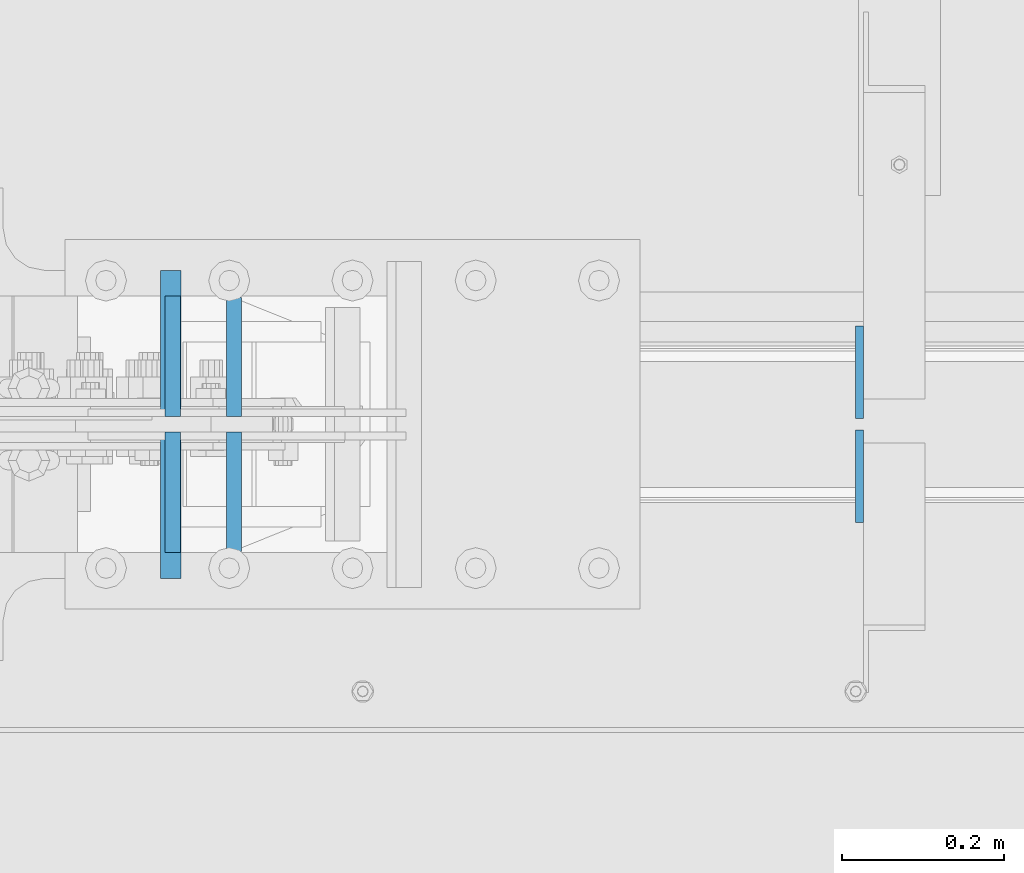
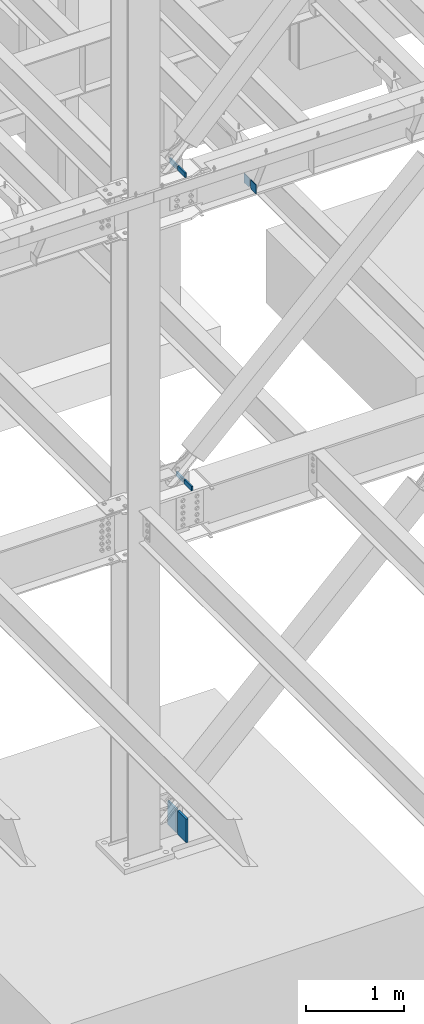
# One storey, part 435 of 1179: 8 columns, 4 elements without a shape of their own.
"""IFC2X3 building model written with IfcOpenShell, lengths in millimetres."""

import ifcopenshell
import ifcopenshell.guid

model = None  # the IFC model being written
_history = None  # IfcOwnerHistory: only IFC2X3 demands one
_inside = {}  # id of a spatial element -> (the spatial element, [elements in it])
_under = {}  # id of a project, library or spatial element -> (it, [spatial elements below it])
_declared = {}  # id of a project -> (the project, [libraries it declares])
_typed = {}  # id of a type object -> (the type object, [elements of that type])
_made_of = {}  # id of a material, layer set ... -> (it, [elements and type objects made of it])


def new_model(schema):
    """Start an empty IFC model of exactly this schema.

    Asked for "IFC4X3", IfcOpenShell would pick the latest addendum, in which some entities
    have other attributes; the version numbers below select the first issue.
    IFC2X3 requires an IfcOwnerHistory on every rooted entity: one is made here for all.
    """
    global model, _history
    if schema == "IFC4X3":
        model = ifcopenshell.file(schema_version=(4, 3, 0, 0))
    else:
        model = ifcopenshell.file(schema=schema)
    _inside.clear()
    _under.clear()
    _declared.clear()
    _typed.clear()
    _made_of.clear()
    _history = None
    if model.schema == "IFC2X3":
        org = make("IfcOrganization", Name="unknown")
        user = make(
            "IfcPersonAndOrganization",
            ThePerson=make("IfcPerson", FamilyName="unknown"),
            TheOrganization=org,
        )
        app = make(
            "IfcApplication",
            ApplicationDeveloper=org,
            Version="unknown",
            ApplicationFullName="unknown",
            ApplicationIdentifier="unknown",
        )
        _history = make(
            "IfcOwnerHistory",
            OwningUser=user,
            OwningApplication=app,
            ChangeAction="ADDED",
            CreationDate=0,
        )
    return model


def make(cls, **values):
    """One entity of the class cls with the attributes given. An attribute that is None is left unset."""
    return model.create_entity(
        cls, **{name: value for name, value in values.items() if value is not None}
    )


def rooted(cls, **values):
    """An entity with a GlobalId (a new one), such as an element, a storey or a relation."""
    return make(cls, GlobalId=ifcopenshell.guid.new(), OwnerHistory=_history, **values)


def si_unit(unit_type, name, prefix=None):
    """IfcSIUnit, for example si_unit("LENGTHUNIT", "METRE", prefix="MILLI")."""
    return make("IfcSIUnit", UnitType=unit_type, Prefix=prefix, Name=name)


def assignment(units):
    """IfcUnitAssignment: the units of a project."""
    return None if units is None else make("IfcUnitAssignment", Units=units)


def point(xyz):
    """IfcCartesianPoint."""
    return None if xyz is None else make("IfcCartesianPoint", Coordinates=xyz)


def direction(xyz):
    """IfcDirection."""
    return None if xyz is None else make("IfcDirection", DirectionRatios=xyz)


def frame(location, z_axis=None, x_axis=None):
    """IfcAxis2Placement3D, a coordinate frame: its origin and axes. An axis left out is left unset."""
    return make(
        "IfcAxis2Placement3D",
        Location=point(location),
        Axis=direction(z_axis),
        RefDirection=direction(x_axis),
    )


def origin_with_axes():
    """The frame at (0, 0, 0) with the z axis (0, 0, 1) and the x axis (1, 0, 0) written out."""
    return frame((0.0, 0.0, 0.0), z_axis=(0.0, 0.0, 1.0), x_axis=(1.0, 0.0, 0.0))


def place(relative_to, where):
    """IfcLocalPlacement: puts the frame where relative to a parent placement (None: the world)."""
    return make(
        "IfcLocalPlacement", PlacementRelTo=relative_to, RelativePlacement=where
    )


def context(
    kind, dimensions, precision=None, world=None, true_north=None, identifier=None
):
    """IfcGeometricRepresentationContext, for example the 3D "Model" context."""
    return make(
        "IfcGeometricRepresentationContext",
        ContextIdentifier=identifier,
        ContextType=kind,
        CoordinateSpaceDimension=dimensions,
        Precision=precision,
        WorldCoordinateSystem=world,
        TrueNorth=true_north,
    )


def subcontext(parent, identifier, kind, view, scale=None):
    """IfcGeometricRepresentationSubContext, for example "Body" below "Model"."""
    return make(
        "IfcGeometricRepresentationSubContext",
        ContextIdentifier=identifier,
        ContextType=kind,
        ParentContext=parent,
        TargetScale=scale,
        TargetView=view,
    )


def project(units=None, contexts=None):
    """IfcProject with its units and contexts."""
    return rooted(
        "IfcProject",
        Name="project",
        RepresentationContexts=contexts,
        UnitsInContext=assignment(units),
    )


def spatial(cls, under=None, at=None, **own):
    """A site, building, storey or space (cls), placed at a placement, below another one or the project."""
    s = rooted(cls, ObjectPlacement=at, **own)
    if under is not None:
        _under.setdefault(under.id(), (under, []))[1].append(s)
    return s


def faces_of(points, faces, orient=None, outer=None):
    """IfcFace entities. A face is a list of loops; a loop is a list of indices into points, from 0.

    orient and outer hold one flag for each loop. By default every Orientation is true, the
    first loop of a face is its IfcFaceOuterBound and the others are IfcFaceBound.
    """
    made = []
    for i, loops in enumerate(faces):
        bounds = []
        for j, loop in enumerate(loops):
            is_outer = j == 0 if outer is None else outer[i][j]
            bounds.append(
                make(
                    "IfcFaceOuterBound" if is_outer else "IfcFaceBound",
                    Bound=make("IfcPolyLoop", Polygon=[points[k] for k in loop]),
                    Orientation=True if orient is None else orient[i][j],
                )
            )
        made.append(make("IfcFace", Bounds=bounds))
    return made


def faceted_brep(points, faces, orient=None, outer=None, voids=None):
    """IfcFacetedBrep: a solid bounded by flat faces; with voids (closed shells), ...WithVoids."""
    shared = [point(p) for p in points]
    hull = make("IfcClosedShell", CfsFaces=faces_of(shared, faces, orient, outer))
    if voids is None:
        return make("IfcFacetedBrep", Outer=hull)
    return make(
        "IfcFacetedBrepWithVoids",
        Outer=hull,
        Voids=[
            make(cls, CfsFaces=faces_of(shared, fs, o, b)) for cls, fs, o, b in voids
        ],
    )


def shape(context_of_items, identifier, shape_type, items):
    """IfcShapeRepresentation: the items that make up one representation, for example the "Body"."""
    return make(
        "IfcShapeRepresentation",
        ContextOfItems=context_of_items,
        RepresentationIdentifier=identifier,
        RepresentationType=shape_type,
        Items=items,
    )


def material(Name=None, Category=None):
    """IfcMaterial."""
    return make("IfcMaterial", Name=Name, Category=Category)


def made_of(thing, what):
    """Note that an element or type object is made of a material, layer set ...; save() writes the relation."""
    if what is not None:
        _made_of.setdefault(what.id(), (what, []))[1].append(thing)
    return thing


def type_object(cls, material=None, **own):
    """A type object (cls), such as IfcWallType, which elements share."""
    return made_of(rooted(cls, **own), material)


def element(
    cls,
    number,
    at=None,
    inside=None,
    cuts=None,
    type_object=None,
    material=None,
    context=None,
    identifier="Body",
    shape_type=None,
    held_by="IfcProductDefinitionShape",
    body=None,
    shapes=None,
    **own,
):
    """One element of the class cls, such as IfcWall. Its Tag is "e" and its number.

    at: its placement. inside: the storey or other place that contains it. cuts: it is an
    opening in that element (IfcRelVoidsElement). A single representation is given by context,
    identifier, shape_type and body (its items); several are given by shapes. held_by: the class
    of the entity that holds the representations. save() writes the other relations.
    """
    e = rooted(cls, Tag="e%d" % number, ObjectPlacement=at, **own)
    if body is not None:
        shapes = [shape(context, identifier, shape_type, body)]
    if shapes is not None:
        e.Representation = make(held_by, Representations=shapes)
    if inside is not None:
        _inside.setdefault(inside.id(), (inside, []))[1].append(e)
    if cuts is not None:
        rooted(
            "IfcRelVoidsElement", RelatingBuildingElement=cuts, RelatedOpeningElement=e
        )
    if type_object is not None:
        _typed.setdefault(type_object.id(), (type_object, []))[1].append(e)
    return made_of(e, material)


def aggregate(whole, parts):
    """IfcRelAggregates: a whole, such as a stair, and the parts it consists of."""
    return rooted("IfcRelAggregates", RelatingObject=whole, RelatedObjects=parts)


def save(model, path):
    """Write the relations noted so far, then the file.

    IfcRelAggregates (storeys below a building ...), IfcRelContainedInSpatialStructure (elements
    in a storey), IfcRelDefinesByType, IfcRelAssociatesMaterial and IfcRelDeclares: one each for
    every whole, place, type object, material and project.
    """
    for whole, parts in _under.values():
        aggregate(whole, parts)
    for where, things in _inside.values():
        rooted(
            "IfcRelContainedInSpatialStructure",
            RelatedElements=things,
            RelatingStructure=where,
        )
    for kind, things in _typed.values():
        rooted("IfcRelDefinesByType", RelatedObjects=things, RelatingType=kind)
    for what, things in _made_of.values():
        rooted("IfcRelAssociatesMaterial", RelatedObjects=things, RelatingMaterial=what)
    for by, libraries in _declared.values():
        rooted("IfcRelDeclares", RelatingContext=by, RelatedDefinitions=libraries)
    model.write(path)


model = new_model("IFC2X3")

# Units and contexts
model_context = context("Model", 3, precision=1e-05, world=origin_with_axes())
body_context = subcontext(model_context, "Body", "Model", "MODEL_VIEW")
ifc_project = project(units=[si_unit("LENGTHUNIT", "METRE", prefix="MILLI"), si_unit("AREAUNIT", "SQUARE_METRE"), si_unit("VOLUMEUNIT", "CUBIC_METRE"), si_unit("MASSUNIT", "GRAM", prefix="KILO"), si_unit("TIMEUNIT", "SECOND"), si_unit("PLANEANGLEUNIT", "RADIAN"), si_unit("SOLIDANGLEUNIT", "STERADIAN"), si_unit("THERMODYNAMICTEMPERATUREUNIT", "DEGREE_CELSIUS"), si_unit("LUMINOUSINTENSITYUNIT", "LUMEN")], contexts=[model_context])

# Site, building, storey
site_placement = place(None, origin_with_axes())
site = spatial("IfcSite", under=ifc_project, at=site_placement, CompositionType="ELEMENT")
building_placement = place(site_placement, origin_with_axes())
building = spatial("IfcBuilding", under=site, at=building_placement, Name="Undefined", CompositionType="ELEMENT")
storey_placement = place(building_placement, origin_with_axes())
storey = spatial("IfcBuildingStorey", under=building, at=storey_placement, Name="Undefined", CompositionType="ELEMENT", Elevation=0.0)

# Assembly, columns
assembly_1_placement = place(storey_placement, origin_with_axes())
assembly_1 = element("IfcElementAssembly", 1, at=assembly_1_placement, inside=storey, Name="BEAM", AssemblyPlace="NOTDEFINED", PredefinedType="RIGID_FRAME")
ifc_material_1 = material(Name="STEEL/A36")
column_type_1 = type_object("IfcColumnType", PredefinedType="NOTDEFINED")
column_1_placement = place(assembly_1_placement, frame((9631.3625, 27115.29375, 7488.2375), z_axis=(0.0, -1.0, 0.0), x_axis=(0.0, 0.0, 1.0)))
column_1 = element("IfcColumn", 2, at=column_1_placement, type_object=column_type_1, material=ifc_material_1, Name="PLATE", context=body_context, shape_type="Brep", body=[
    faceted_brep([(22.2250000000004, 4.76250000000073, 57.1500000000015), (0.0, 4.76250000000073, 34.9249999999993), (0.0, -4.76250000000073, 34.9249999999993), (22.2250000000004, -4.76250000000073, 57.1500000000015), (114.300000000001, 4.76250000000073, 57.1500000000015), (114.300000000001, 4.76250000000073, -57.1500000000015), (0.0, 4.76250000000073, -57.1500000000015), (114.300000000001, -4.76250000000073, 57.1500000000015), (0.0, -4.76250000000073, -57.1500000000015), (114.300000000001, -4.76250000000073, -57.1500000000015)], [[[0, 1, 2, 3]], [[4, 5, 6, 1, 0]], [[7, 4, 0, 3]], [[8, 9, 7, 3, 2]], [[8, 6, 5, 9]], [[7, 9, 5, 4]], [[6, 8, 2, 1]]]),
])
column_2_placement = place(assembly_1_placement, frame((9631.3625, 26986.70625, 7488.2375), z_axis=(0.0, 1.0, 0.0), x_axis=(0.0, 0.0, 1.0)))
column_2 = element("IfcColumn", 3, at=column_2_placement, type_object=column_type_1, material=ifc_material_1, Name="PLATE", context=body_context, shape_type="Brep", body=[
    faceted_brep([(22.2250000000004, 4.76250000000073, 57.1500000000015), (0.0, 4.76250000000073, 34.9249999999993), (0.0, -4.76250000000073, 34.9249999999993), (22.2250000000004, -4.76250000000073, 57.1500000000015), (114.300000000001, 4.76250000000073, 57.1500000000015), (114.300000000001, 4.76250000000073, -57.1500000000015), (0.0, 4.76250000000073, -57.1500000000015), (114.300000000001, -4.76250000000073, 57.1500000000015), (0.0, -4.76250000000073, -57.1500000000015), (114.300000000001, -4.76250000000073, -57.1500000000015)], [[[0, 1, 2, 3]], [[4, 5, 6, 1, 0]], [[7, 4, 0, 3]], [[8, 9, 7, 3, 2]], [[8, 6, 5, 9]], [[7, 9, 5, 4]], [[6, 8, 2, 1]]]),
])
aggregate(assembly_1, [column_1, column_2])

assembly_2_placement = place(storey_placement, origin_with_axes())
assembly_2 = element("IfcElementAssembly", 4, at=assembly_2_placement, inside=storey, Name="COLUMN", AssemblyPlace="NOTDEFINED", PredefinedType="RIGID_FRAME")
ifc_material_2 = material(Name="STEEL/A572-GR.50")
column_type_2 = type_object("IfcColumnType", PredefinedType="NOTDEFINED")
column_3_placement = place(assembly_2_placement, frame((8857.853125, 26967.6562863882, 4102.1), z_axis=(0.0, 1.0, 0.0), x_axis=(0.0, 0.0, 1.0)))
column_3 = element("IfcColumn", 5, at=column_3_placement, type_object=column_type_2, material=ifc_material_2, Name="PLATE", context=body_context, shape_type="Brep", body=[
    faceted_brep([(0.0, 9.52499999999964, -73.8189999999995), (0.0, 9.52499999999964, 73.8189999999995), (51.3564167127251, 9.52499999999964, 73.8189999999995), (51.3564167127251, 9.52499999999964, -73.8189999999995), (0.0, -9.52499999999964, 73.8189999999995), (51.3564167127251, -9.52499999999964, 73.8189999999995), (0.0, -9.52499999999964, -73.8189999999995), (51.3564167127251, -9.52499999999964, -73.8189999999995)], [[[0, 1, 2, 3]], [[1, 4, 5, 2]], [[4, 6, 7, 5]], [[6, 0, 3, 7]], [[5, 7, 3, 2]], [[6, 4, 1, 0]]]),
])
column_4_placement = place(assembly_2_placement, frame((8857.853125, 27134.3437136118, 4102.1), z_axis=(0.0, -1.0, 0.0), x_axis=(0.0, 0.0, 1.0)))
column_4 = element("IfcColumn", 6, at=column_4_placement, type_object=column_type_2, material=ifc_material_2, Name="PLATE", context=body_context, shape_type="Brep", body=[
    faceted_brep([(0.0, 9.52499999999964, -73.8189999999995), (0.0, 9.52499999999964, 73.8189999999995), (51.3564167127251, 9.52499999999964, 73.8189999999995), (51.3564167127251, 9.52499999999964, -73.8189999999995), (0.0, -9.52499999999964, 73.8189999999995), (51.3564167127251, -9.52499999999964, 73.8189999999995), (0.0, -9.52499999999964, -73.8189999999995), (51.3564167127251, -9.52499999999964, -73.8189999999995)], [[[0, 1, 2, 3]], [[1, 4, 5, 2]], [[4, 6, 7, 5]], [[6, 0, 3, 7]], [[5, 7, 3, 2]], [[6, 4, 1, 0]]]),
])

# Assembly, column
assembly_3_placement = place(storey_placement, origin_with_axes())
assembly_3 = element("IfcElementAssembly", 7, at=assembly_3_placement, inside=storey, Name="PLATE", AssemblyPlace="NOTDEFINED", PredefinedType="RIGID_FRAME")
column_type_3 = type_object("IfcColumnType", PredefinedType="NOTDEFINED")
column_5_placement = place(assembly_3_placement, frame((8779.73164236645, 27152.6, -215.9), z_axis=(0.0, -1.0, 0.0), x_axis=(0.0, 0.0, 1.0)))
column_5 = element("IfcColumn", 8, at=column_5_placement, type_object=column_type_3, material=ifc_material_2, Name="PLATE", context=body_context, shape_type="Brep", body=[
    faceted_brep([(0.0, 12.6999999999998, -88.9000000000015), (0.0, 12.6999999999998, 88.9000000000015), (291.683174367477, 12.7000000000007, 88.9000000000015), (291.683174367477, 12.7000000000007, -88.9000000000015), (0.0, -12.6999999999998, 88.9000000000015), (291.683174367477, -12.7000000000007, 88.9000000000015), (0.0, -12.6999999999998, -88.9000000000015), (291.683174367477, -12.7000000000007, -88.9000000000015)], [[[0, 1, 2, 3]], [[1, 4, 5, 2]], [[4, 6, 7, 5]], [[6, 0, 3, 7]], [[5, 7, 3, 2]], [[6, 4, 1, 0]]]),
])
aggregate(assembly_3, [column_5])

assembly_4_placement = place(storey_placement, origin_with_axes())
assembly_4 = element("IfcElementAssembly", 9, at=assembly_4_placement, inside=storey, Name="PLATE", AssemblyPlace="NOTDEFINED", PredefinedType="RIGID_FRAME")
column_6_placement = place(assembly_4_placement, frame((8779.73164236645, 26949.4, -215.9), z_axis=(0.0, 1.0, 0.0), x_axis=(0.0, 0.0, 1.0)))
column_6 = element("IfcColumn", 10, at=column_6_placement, type_object=column_type_3, material=ifc_material_2, Name="PLATE", context=body_context, shape_type="Brep", body=[
    faceted_brep([(0.0, 12.6999999999998, -88.9000000000015), (0.0, 12.6999999999998, 88.9000000000015), (291.683174367477, 12.7000000000007, 88.9000000000015), (291.683174367477, 12.7000000000007, -88.9000000000015), (0.0, -12.6999999999998, 88.9000000000015), (291.683174367477, -12.7000000000007, 88.9000000000015), (0.0, -12.6999999999998, -88.9000000000015), (291.683174367477, -12.7000000000007, -88.9000000000015)], [[[0, 1, 2, 3]], [[1, 4, 5, 2]], [[4, 6, 7, 5]], [[6, 0, 3, 7]], [[5, 7, 3, 2]], [[6, 4, 1, 0]]]),
])
aggregate(assembly_4, [column_6])

# Column
column_type_4 = type_object("IfcColumnType", PredefinedType="NOTDEFINED")
column_7_placement = place(assembly_2_placement, frame((8782.05891856911, 27135.1375, 8013.7), z_axis=(0.0, -1.0, 0.0), x_axis=(0.0, 0.0, 1.0)))
column_7 = element("IfcColumn", 11, at=column_7_placement, type_object=column_type_4, material=ifc_material_2, Name="PLATE", context=body_context, shape_type="Brep", body=[
    faceted_brep([(0.0, 9.52499999999964, -74.6124999999993), (0.0, 9.52499999999964, 74.6124999999993), (58.2260027054381, 9.52499999999964, 74.6124999999993), (58.2260027054381, 9.52499999999964, -74.6124999999993), (0.0, -9.52499999999964, 74.6124999999993), (58.2260027054381, -9.52499999999964, 74.6124999999993), (0.0, -9.52499999999964, -74.6124999999993), (58.2260027054381, -9.52499999999964, -74.6124999999993)], [[[0, 1, 2, 3]], [[1, 4, 5, 2]], [[4, 6, 7, 5]], [[6, 0, 3, 7]], [[5, 7, 3, 2]], [[6, 4, 1, 0]]]),
])

column_8_placement = place(assembly_2_placement, frame((8782.05891856911, 26966.8625, 8013.7), z_axis=(0.0, 1.0, 0.0), x_axis=(0.0, 0.0, 1.0)))
column_8 = element("IfcColumn", 12, at=column_8_placement, type_object=column_type_4, material=ifc_material_2, Name="PLATE", context=body_context, shape_type="Brep", body=[
    faceted_brep([(0.0, 9.52499999999964, -74.6124999999993), (0.0, 9.52499999999964, 74.6124999999993), (58.2260027054381, 9.52499999999964, 74.6124999999993), (58.2260027054381, 9.52499999999964, -74.6124999999993), (0.0, -9.52499999999964, 74.6124999999993), (58.2260027054381, -9.52499999999964, 74.6124999999993), (0.0, -9.52499999999964, -74.6124999999993), (58.2260027054381, -9.52499999999964, -74.6124999999993)], [[[0, 1, 2, 3]], [[1, 4, 5, 2]], [[4, 6, 7, 5]], [[6, 0, 3, 7]], [[5, 7, 3, 2]], [[6, 4, 1, 0]]]),
])

aggregate(assembly_2, [column_3, column_4, column_7, column_8])

save(model, "model.ifc")
